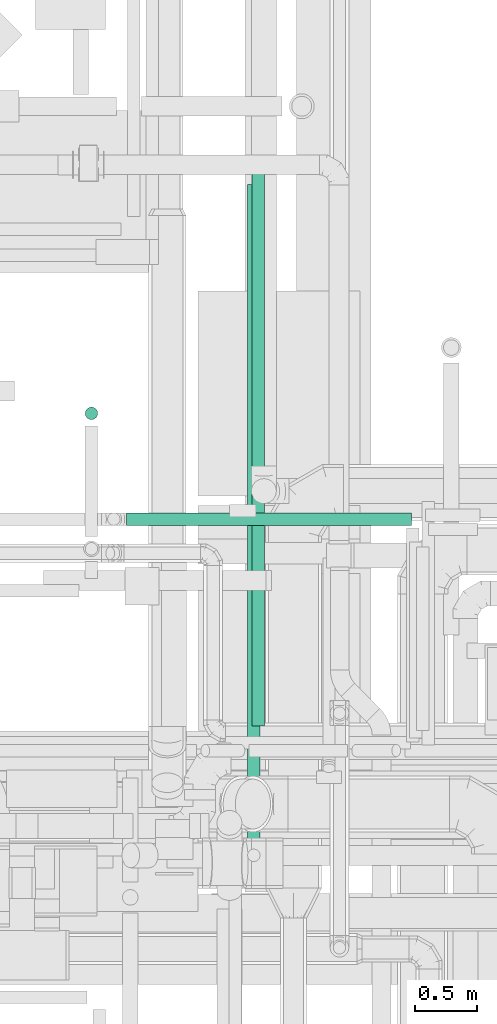
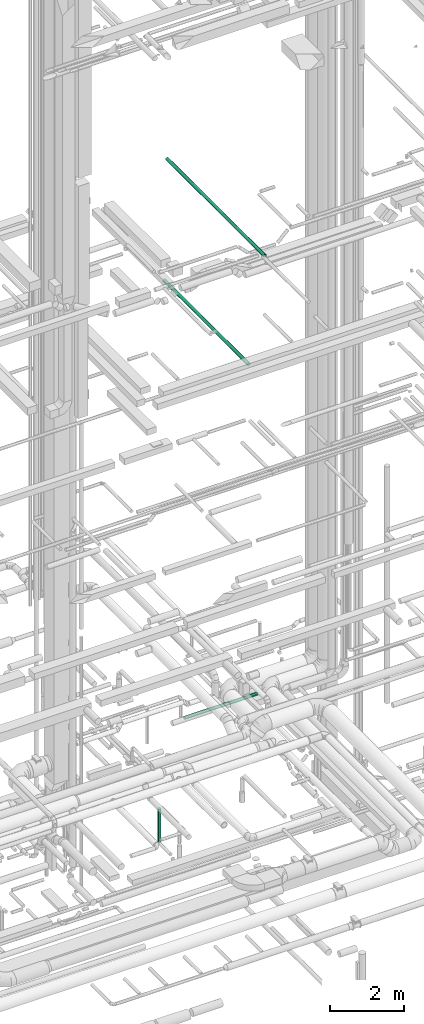
# One storey, part 68 of 337: 4 flow segments.
"""IFC2X3 building model written with IfcOpenShell, lengths in millimetres."""

from ifc_helpers import new_model, entity, si_unit, converted_unit, derived_unit, direction, frame, origin, origin_2d_with_axis, place, context, subcontext, project, spatial, circle, extrude, type_object, element, save


model = new_model("IFC2X3")

# Units and contexts
model_context = context("Model", 3, precision=0.01, world=origin(), true_north=direction((6.12303176911189e-17, 1.0)))
body_context = subcontext(model_context, "Body", "Model", "MODEL_VIEW")
ifc_project = project(units=[si_unit("LENGTHUNIT", "METRE", prefix="MILLI"), si_unit("AREAUNIT", "SQUARE_METRE"), si_unit("VOLUMEUNIT", "CUBIC_METRE"), converted_unit("PLANEANGLEUNIT", "DEGREE", entity("IfcRatioMeasure", 0.0174532925199433), si_unit("PLANEANGLEUNIT", "RADIAN"), dimensions=[0, 0, 0, 0, 0, 0, 0]), si_unit("MASSUNIT", "GRAM", prefix="KILO"), derived_unit("MASSDENSITYUNIT", [(si_unit("MASSUNIT", "GRAM", prefix="KILO"), 1), (si_unit("LENGTHUNIT", "METRE"), -3)]), derived_unit("MOMENTOFINERTIAUNIT", [(si_unit("LENGTHUNIT", "METRE"), 4)]), si_unit("TIMEUNIT", "SECOND"), si_unit("FREQUENCYUNIT", "HERTZ"), si_unit("THERMODYNAMICTEMPERATUREUNIT", "DEGREE_CELSIUS"), derived_unit("THERMALTRANSMITTANCEUNIT", [(si_unit("MASSUNIT", "GRAM", prefix="KILO"), 1), (si_unit("THERMODYNAMICTEMPERATUREUNIT", "KELVIN"), -1), (si_unit("TIMEUNIT", "SECOND"), -3)]), derived_unit("VOLUMETRICFLOWRATEUNIT", [(si_unit("LENGTHUNIT", "METRE"), 3), (si_unit("TIMEUNIT", "SECOND"), -1)]), derived_unit("MASSFLOWRATEUNIT", [(si_unit("MASSUNIT", "GRAM", prefix="KILO"), 1), (si_unit("TIMEUNIT", "SECOND"), -1)]), derived_unit("ROTATIONALFREQUENCYUNIT", [(si_unit("TIMEUNIT", "SECOND"), -1)]), si_unit("ELECTRICCURRENTUNIT", "AMPERE"), si_unit("ELECTRICVOLTAGEUNIT", "VOLT"), si_unit("POWERUNIT", "WATT"), si_unit("FORCEUNIT", "NEWTON", prefix="KILO"), si_unit("ILLUMINANCEUNIT", "LUX"), si_unit("LUMINOUSFLUXUNIT", "LUMEN"), si_unit("LUMINOUSINTENSITYUNIT", "CANDELA"), derived_unit("USERDEFINED", [(si_unit("MASSUNIT", "GRAM", prefix="KILO"), -1), (si_unit("LENGTHUNIT", "METRE"), -2), (si_unit("TIMEUNIT", "SECOND"), 3), (si_unit("LUMINOUSFLUXUNIT", "LUMEN"), 1)]), derived_unit("LINEARVELOCITYUNIT", [(si_unit("LENGTHUNIT", "METRE"), 1), (si_unit("TIMEUNIT", "SECOND"), -1)]), si_unit("PRESSUREUNIT", "PASCAL"), derived_unit("USERDEFINED", [(si_unit("LENGTHUNIT", "METRE"), -2), (si_unit("MASSUNIT", "GRAM", prefix="KILO"), 1), (si_unit("TIMEUNIT", "SECOND"), -2)]), derived_unit("LINEARFORCEUNIT", [(si_unit("MASSUNIT", "GRAM", prefix="KILO"), 1), (si_unit("LENGTHUNIT", "METRE"), 1), (si_unit("TIMEUNIT", "SECOND"), -2), (si_unit("LENGTHUNIT", "METRE"), -1)]), derived_unit("PLANARFORCEUNIT", [(si_unit("MASSUNIT", "GRAM", prefix="KILO"), 1), (si_unit("LENGTHUNIT", "METRE"), 1), (si_unit("TIMEUNIT", "SECOND"), -2), (si_unit("LENGTHUNIT", "METRE"), -2)])], contexts=[model_context])

# Site, building, storey
site_placement = place(None, origin())
site = spatial("IfcSite", under=ifc_project, at=site_placement, CompositionType="ELEMENT")
building_placement = place(site_placement, origin())
building = spatial("IfcBuilding", under=site, at=building_placement, CompositionType="ELEMENT")
storey_placement = place(building_placement, origin())
storey = spatial("IfcBuildingStorey", under=building, at=storey_placement, CompositionType="ELEMENT", Elevation=0.0)

# Flow segments
duct_segment_type = type_object("IfcDuctSegmentType", PredefinedType="NOTDEFINED")
flow_segment_1_placement = place(storey_placement, frame((62974.94, 12833.07, -1800.0)))
element("IfcFlowSegment", 1, at=flow_segment_1_placement, inside=storey, type_object=duct_segment_type, context=body_context, shape_type="SweptSolid", body=[
    extrude(circle(Radius=50.0, at=origin_2d_with_axis()), frame((51.6, 51.6, 0.0), z_axis=(0.0, 0.0, 1.0), x_axis=(-1.0, 0.0, 0.0)), (0.0, 0.0, 1.0), 1100.00000000001),
])
flow_segment_2_placement = place(storey_placement, frame((64277.72, 9438.57, 19098.4)))
element("IfcFlowSegment", 2, at=flow_segment_2_placement, inside=storey, type_object=duct_segment_type, context=body_context, shape_type="SweptSolid", body=[
    extrude(circle(Radius=50.0, at=origin_2d_with_axis()), frame((51.6, 0.0, 51.6), z_axis=(0.0, 1.0, 0.0), x_axis=(1.0, 0.0, 0.0)), (0.0, 0.0, 1.0), 5281.91850898786),
])
flow_segment_3_placement = place(storey_placement, frame((64313.43, 10375.04, 14948.4)))
element("IfcFlowSegment", 3, at=flow_segment_3_placement, inside=storey, type_object=duct_segment_type, context=body_context, shape_type="SweptSolid", body=[
    extrude(circle(Radius=50.0, at=origin_2d_with_axis()), frame((51.6, 0.0, 51.6), z_axis=(0.0, 1.0, 0.0), x_axis=(1.0, 0.0, 0.0)), (0.0, 0.0, 1.0), 4565.30000000002),
])
flow_segment_4_placement = place(storey_placement, frame((63305.86, 11984.54, 2648.4)))
element("IfcFlowSegment", 4, at=flow_segment_4_placement, inside=storey, type_object=duct_segment_type, context=body_context, shape_type="SweptSolid", body=[
    extrude(circle(Radius=50.0, at=origin_2d_with_axis()), frame((0.0, 51.6, 51.6), z_axis=(1.0, 0.0, 0.0), x_axis=(0.0, -1.0, 0.0)), (0.0, 0.0, 1.0), 2286.83766184075),
])

save(model, "model.ifc")
